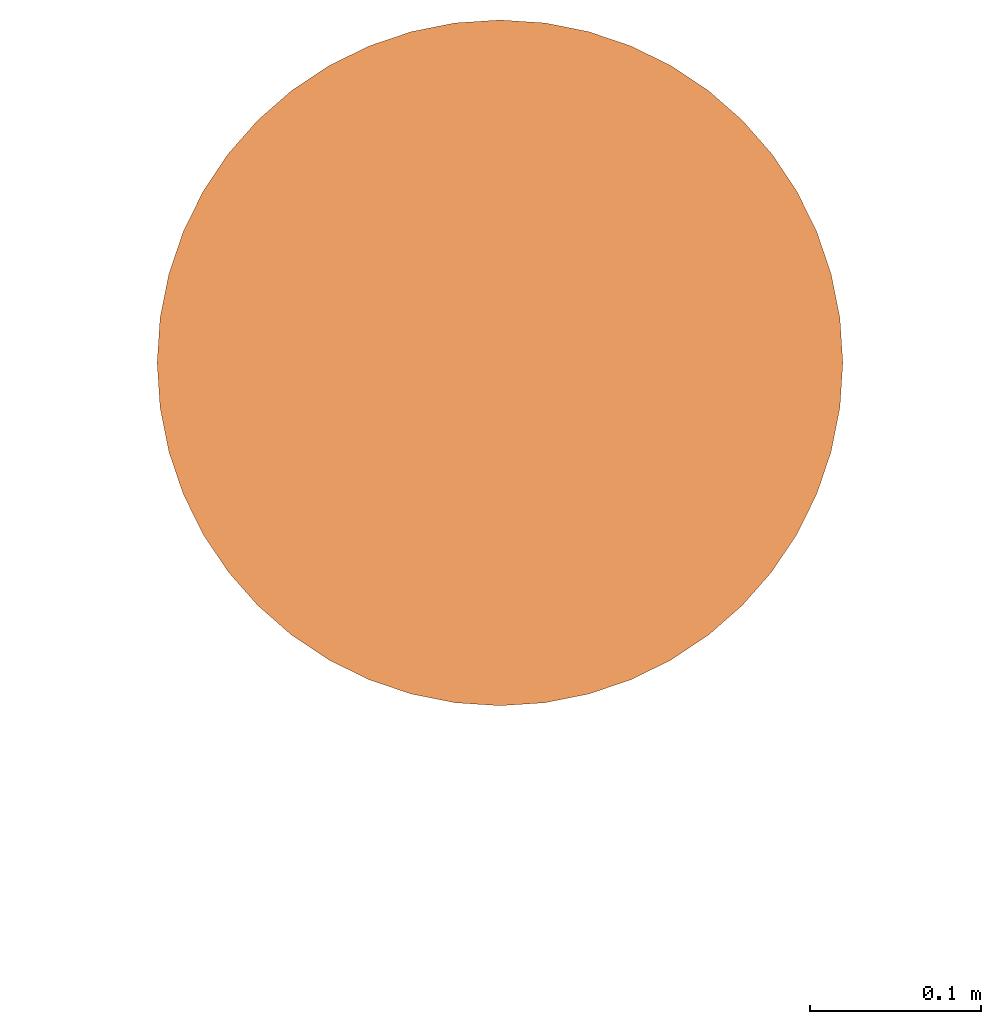
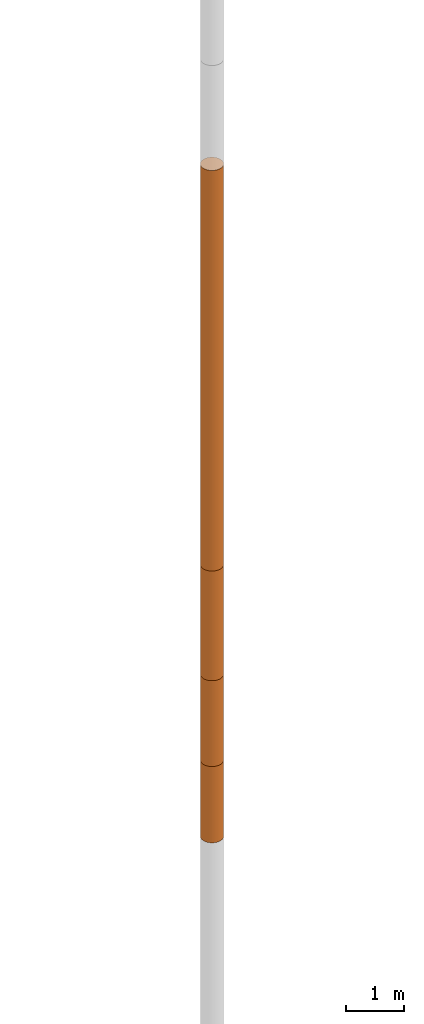
# Not in any storey, part 4 of 5: 4 geographic elements.
"""IFC4 model written with IfcOpenShell, lengths in metres."""

from ifc_helpers import new_model, entity, si_unit, converted_unit, frame, frame_2d, origin_with_axes, place, context, subcontext, project, spatial, polygons, element, save


model = new_model("IFC4")

# Units and contexts
model_context = context("Model", 3, precision=1e-05, world=origin_with_axes())
plan_context = context("Plan", 2, precision=1e-05, world=frame_2d((0.0, 0.0, 0.0), x_axis=(1.0, 0.0, 0.0)))
body_context = subcontext(model_context, "Body", "Model", "MODEL_VIEW")
ifc_project = project(units=[si_unit("VOLUMEUNIT", "CUBIC_METRE"), si_unit("LENGTHUNIT", "METRE"), converted_unit("PLANEANGLEUNIT", "degree", entity("IfcReal", 0.0174532925199433), si_unit("PLANEANGLEUNIT", "RADIAN"), dimensions=[0, 0, 0, 0, 0, 0, 0]), si_unit("AREAUNIT", "SQUARE_METRE")], contexts=[model_context, plan_context])

# Site
site_placement = place(None, origin_with_axes())
site = spatial("IfcSite", under=ifc_project, at=site_placement)

# Geographic elements
geographic_element_1_placement = place(site_placement, frame((19.3999996185303, 90.9000015258789, 3.20000457763672), z_axis=(0.0, 0.0, 1.0), x_axis=(1.0, 0.0, 0.0)))
element("IfcGeographicElement", 1, at=geographic_element_1_placement, inside=site, Name="BH_1_L_4", PredefinedType="NOTDEFINED", context=body_context, shape_type="Tessellation", body=[
    polygons([(0.0, 0.200000002980232, -4.19999980926514), (0.0, 0.200000002980232, 4.19999980926514), (0.0261052399873734, 0.198288977146149, -4.19999980926514), (0.0261052399873734, 0.198288977146149, 4.19999980926514), (0.0517638102173805, 0.193185165524483, -4.19999980926514), (0.0517638102173805, 0.193185165524483, 4.19999980926514), (0.0765366926789284, 0.184775903820992, -4.19999980926514), (0.0765366926789284, 0.184775903820992, 4.19999980926514), (0.100000001490116, 0.173205077648163, -4.19999980926514), (0.100000001490116, 0.173205077648163, 4.19999980926514), (0.12175228446722, 0.158670663833618, -4.19999980926514), (0.12175228446722, 0.158670663833618, 4.19999980926514), (0.141421362757683, 0.141421362757683, -4.19999980926514), (0.141421362757683, 0.141421362757683, 4.19999980926514), (0.158670663833618, 0.12175228446722, -4.19999980926514), (0.158670663833618, 0.12175228446722, 4.19999980926514), (0.173205077648163, 0.100000001490116, -4.19999980926514), (0.173205077648163, 0.100000001490116, 4.19999980926514), (0.184775903820992, 0.0765366926789284, -4.19999980926514), (0.184775903820992, 0.0765366926789284, 4.19999980926514), (0.193185165524483, 0.0517638102173805, -4.19999980926514), (0.193185165524483, 0.0517638102173805, 4.19999980926514), (0.198288977146149, 0.0261052399873734, -4.19999980926514), (0.198288977146149, 0.0261052399873734, 4.19999980926514), (0.200000002980232, 0.0, -4.19999980926514), (0.200000002980232, 0.0, 4.19999980926514), (0.198288977146149, -0.0261052399873734, -4.19999980926514), (0.198288977146149, -0.0261052399873734, 4.19999980926514), (0.193185165524483, -0.0517638102173805, -4.19999980926514), (0.193185165524483, -0.0517638102173805, 4.19999980926514), (0.184775903820992, -0.0765366926789284, -4.19999980926514), (0.184775903820992, -0.0765366926789284, 4.19999980926514), (0.173205077648163, -0.100000001490116, -4.19999980926514), (0.173205077648163, -0.100000001490116, 4.19999980926514), (0.158670663833618, -0.12175228446722, -4.19999980926514), (0.158670663833618, -0.12175228446722, 4.19999980926514), (0.141421362757683, -0.141421362757683, -4.19999980926514), (0.141421362757683, -0.141421362757683, 4.19999980926514), (0.12175228446722, -0.158670663833618, -4.19999980926514), (0.12175228446722, -0.158670663833618, 4.19999980926514), (0.100000001490116, -0.173205077648163, -4.19999980926514), (0.100000001490116, -0.173205077648163, 4.19999980926514), (0.0765366926789284, -0.184775903820992, -4.19999980926514), (0.0765366926789284, -0.184775903820992, 4.19999980926514), (0.0517638102173805, -0.193185165524483, -4.19999980926514), (0.0517638102173805, -0.193185165524483, 4.19999980926514), (0.0261052399873734, -0.198288977146149, -4.19999980926514), (0.0261052399873734, -0.198288977146149, 4.19999980926514), (0.0, -0.200000002980232, -4.19999980926514), (0.0, -0.200000002980232, 4.19999980926514), (-0.0261052399873734, -0.198288977146149, -4.19999980926514), (-0.0261052399873734, -0.198288977146149, 4.19999980926514), (-0.0517638102173805, -0.193185165524483, -4.19999980926514), (-0.0517638102173805, -0.193185165524483, 4.19999980926514), (-0.0765366926789284, -0.184775903820992, -4.19999980926514), (-0.0765366926789284, -0.184775903820992, 4.19999980926514), (-0.100000001490116, -0.173205077648163, -4.19999980926514), (-0.100000001490116, -0.173205077648163, 4.19999980926514), (-0.12175228446722, -0.158670663833618, -4.19999980926514), (-0.12175228446722, -0.158670663833618, 4.19999980926514), (-0.141421362757683, -0.141421362757683, -4.19999980926514), (-0.141421362757683, -0.141421362757683, 4.19999980926514), (-0.158670663833618, -0.12175228446722, -4.19999980926514), (-0.158670663833618, -0.12175228446722, 4.19999980926514), (-0.173205077648163, -0.100000001490116, -4.19999980926514), (-0.173205077648163, -0.100000001490116, 4.19999980926514), (-0.184775903820992, -0.0765366926789284, -4.19999980926514), (-0.184775903820992, -0.0765366926789284, 4.19999980926514), (-0.193185165524483, -0.0517638102173805, -4.19999980926514), (-0.193185165524483, -0.0517638102173805, 4.19999980926514), (-0.198288977146149, -0.0261052399873734, -4.19999980926514), (-0.198288977146149, -0.0261052399873734, 4.19999980926514), (-0.200000002980232, 0.0, -4.19999980926514), (-0.200000002980232, 0.0, 4.19999980926514), (-0.198288977146149, 0.0261052399873734, -4.19999980926514), (-0.198288977146149, 0.0261052399873734, 4.19999980926514), (-0.193185165524483, 0.0517638102173805, -4.19999980926514), (-0.193185165524483, 0.0517638102173805, 4.19999980926514), (-0.184775903820992, 0.0765366926789284, -4.19999980926514), (-0.184775903820992, 0.0765366926789284, 4.19999980926514), (-0.173205077648163, 0.100000001490116, -4.19999980926514), (-0.173205077648163, 0.100000001490116, 4.19999980926514), (-0.158670663833618, 0.12175228446722, -4.19999980926514), (-0.158670663833618, 0.12175228446722, 4.19999980926514), (-0.141421362757683, 0.141421362757683, -4.19999980926514), (-0.141421362757683, 0.141421362757683, 4.19999980926514), (-0.12175228446722, 0.158670663833618, -4.19999980926514), (-0.12175228446722, 0.158670663833618, 4.19999980926514), (-0.100000001490116, 0.173205077648163, -4.19999980926514), (-0.100000001490116, 0.173205077648163, 4.19999980926514), (-0.0765366926789284, 0.184775903820992, -4.19999980926514), (-0.0765366926789284, 0.184775903820992, 4.19999980926514), (-0.0517638102173805, 0.193185165524483, -4.19999980926514), (-0.0517638102173805, 0.193185165524483, 4.19999980926514), (-0.0261052399873734, 0.198288977146149, -4.19999980926514), (-0.0261052399873734, 0.198288977146149, 4.19999980926514)], [[[1, 2, 4, 3]], [[3, 4, 6, 5]], [[5, 6, 8, 7]], [[7, 8, 10, 9]], [[9, 10, 12, 11]], [[11, 12, 14, 13]], [[13, 14, 16, 15]], [[15, 16, 18, 17]], [[17, 18, 20, 19]], [[19, 20, 22, 21]], [[21, 22, 24, 23]], [[23, 24, 26, 25]], [[25, 26, 28, 27]], [[27, 28, 30, 29]], [[29, 30, 32, 31]], [[31, 32, 34, 33]], [[33, 34, 36, 35]], [[35, 36, 38, 37]], [[37, 38, 40, 39]], [[39, 40, 42, 41]], [[41, 42, 44, 43]], [[43, 44, 46, 45]], [[45, 46, 48, 47]], [[47, 48, 50, 49]], [[49, 50, 52, 51]], [[51, 52, 54, 53]], [[53, 54, 56, 55]], [[55, 56, 58, 57]], [[57, 58, 60, 59]], [[59, 60, 62, 61]], [[61, 62, 64, 63]], [[63, 64, 66, 65]], [[65, 66, 68, 67]], [[67, 68, 70, 69]], [[69, 70, 72, 71]], [[71, 72, 74, 73]], [[73, 74, 76, 75]], [[75, 76, 78, 77]], [[77, 78, 80, 79]], [[79, 80, 82, 81]], [[81, 82, 84, 83]], [[83, 84, 86, 85]], [[85, 86, 88, 87]], [[87, 88, 90, 89]], [[89, 90, 92, 91]], [[91, 92, 94, 93]], [[4, 2, 96, 94, 92, 90, 88, 86, 84, 82, 80, 78, 76, 74, 72, 70, 68, 66, 64, 62, 60, 58, 56, 54, 52, 50, 48, 46, 44, 42, 40, 38, 36, 34, 32, 30, 28, 26, 24, 22, 20, 18, 16, 14, 12, 10, 8, 6]], [[93, 94, 96, 95]], [[95, 96, 2, 1]], [[1, 3, 5, 7, 9, 11, 13, 15, 17, 19, 21, 23, 25, 27, 29, 31, 33, 35, 37, 39, 41, 43, 45, 47, 49, 51, 53, 55, 57, 59, 61, 63, 65, 67, 69, 71, 73, 75, 77, 79, 81, 83, 85, 87, 89, 91, 93, 95]]]),
])
geographic_element_2_placement = place(site_placement, frame((19.3999996185303, 90.9000015258789, -2.14999341964722), z_axis=(0.0, 0.0, 1.0), x_axis=(1.0, 0.0, 0.0)))
element("IfcGeographicElement", 2, at=geographic_element_2_placement, inside=site, Name="BH_1_L_5", PredefinedType="NOTDEFINED", context=body_context, shape_type="Tessellation", body=[
    polygons([(0.0, 0.200000002980232, -1.14999997615814), (0.0, 0.200000002980232, 1.14999997615814), (0.0261052399873734, 0.198288977146149, -1.14999997615814), (0.0261052399873734, 0.198288977146149, 1.14999997615814), (0.0517638102173805, 0.193185165524483, -1.14999997615814), (0.0517638102173805, 0.193185165524483, 1.14999997615814), (0.0765366926789284, 0.184775903820992, -1.14999997615814), (0.0765366926789284, 0.184775903820992, 1.14999997615814), (0.100000001490116, 0.173205077648163, -1.14999997615814), (0.100000001490116, 0.173205077648163, 1.14999997615814), (0.12175228446722, 0.158670663833618, -1.14999997615814), (0.12175228446722, 0.158670663833618, 1.14999997615814), (0.141421362757683, 0.141421362757683, -1.14999997615814), (0.141421362757683, 0.141421362757683, 1.14999997615814), (0.158670663833618, 0.12175228446722, -1.14999997615814), (0.158670663833618, 0.12175228446722, 1.14999997615814), (0.173205077648163, 0.100000001490116, -1.14999997615814), (0.173205077648163, 0.100000001490116, 1.14999997615814), (0.184775903820992, 0.0765366926789284, -1.14999997615814), (0.184775903820992, 0.0765366926789284, 1.14999997615814), (0.193185165524483, 0.0517638102173805, -1.14999997615814), (0.193185165524483, 0.0517638102173805, 1.14999997615814), (0.198288977146149, 0.0261052399873734, -1.14999997615814), (0.198288977146149, 0.0261052399873734, 1.14999997615814), (0.200000002980232, 0.0, -1.14999997615814), (0.200000002980232, 0.0, 1.14999997615814), (0.198288977146149, -0.0261052399873734, -1.14999997615814), (0.198288977146149, -0.0261052399873734, 1.14999997615814), (0.193185165524483, -0.0517638102173805, -1.14999997615814), (0.193185165524483, -0.0517638102173805, 1.14999997615814), (0.184775903820992, -0.0765366926789284, -1.14999997615814), (0.184775903820992, -0.0765366926789284, 1.14999997615814), (0.173205077648163, -0.100000001490116, -1.14999997615814), (0.173205077648163, -0.100000001490116, 1.14999997615814), (0.158670663833618, -0.12175228446722, -1.14999997615814), (0.158670663833618, -0.12175228446722, 1.14999997615814), (0.141421362757683, -0.141421362757683, -1.14999997615814), (0.141421362757683, -0.141421362757683, 1.14999997615814), (0.12175228446722, -0.158670663833618, -1.14999997615814), (0.12175228446722, -0.158670663833618, 1.14999997615814), (0.100000001490116, -0.173205077648163, -1.14999997615814), (0.100000001490116, -0.173205077648163, 1.14999997615814), (0.0765366926789284, -0.184775903820992, -1.14999997615814), (0.0765366926789284, -0.184775903820992, 1.14999997615814), (0.0517638102173805, -0.193185165524483, -1.14999997615814), (0.0517638102173805, -0.193185165524483, 1.14999997615814), (0.0261052399873734, -0.198288977146149, -1.14999997615814), (0.0261052399873734, -0.198288977146149, 1.14999997615814), (0.0, -0.200000002980232, -1.14999997615814), (0.0, -0.200000002980232, 1.14999997615814), (-0.0261052399873734, -0.198288977146149, -1.14999997615814), (-0.0261052399873734, -0.198288977146149, 1.14999997615814), (-0.0517638102173805, -0.193185165524483, -1.14999997615814), (-0.0517638102173805, -0.193185165524483, 1.14999997615814), (-0.0765366926789284, -0.184775903820992, -1.14999997615814), (-0.0765366926789284, -0.184775903820992, 1.14999997615814), (-0.100000001490116, -0.173205077648163, -1.14999997615814), (-0.100000001490116, -0.173205077648163, 1.14999997615814), (-0.12175228446722, -0.158670663833618, -1.14999997615814), (-0.12175228446722, -0.158670663833618, 1.14999997615814), (-0.141421362757683, -0.141421362757683, -1.14999997615814), (-0.141421362757683, -0.141421362757683, 1.14999997615814), (-0.158670663833618, -0.12175228446722, -1.14999997615814), (-0.158670663833618, -0.12175228446722, 1.14999997615814), (-0.173205077648163, -0.100000001490116, -1.14999997615814), (-0.173205077648163, -0.100000001490116, 1.14999997615814), (-0.184775903820992, -0.0765366926789284, -1.14999997615814), (-0.184775903820992, -0.0765366926789284, 1.14999997615814), (-0.193185165524483, -0.0517638102173805, -1.14999997615814), (-0.193185165524483, -0.0517638102173805, 1.14999997615814), (-0.198288977146149, -0.0261052399873734, -1.14999997615814), (-0.198288977146149, -0.0261052399873734, 1.14999997615814), (-0.200000002980232, 0.0, -1.14999997615814), (-0.200000002980232, 0.0, 1.14999997615814), (-0.198288977146149, 0.0261052399873734, -1.14999997615814), (-0.198288977146149, 0.0261052399873734, 1.14999997615814), (-0.193185165524483, 0.0517638102173805, -1.14999997615814), (-0.193185165524483, 0.0517638102173805, 1.14999997615814), (-0.184775903820992, 0.0765366926789284, -1.14999997615814), (-0.184775903820992, 0.0765366926789284, 1.14999997615814), (-0.173205077648163, 0.100000001490116, -1.14999997615814), (-0.173205077648163, 0.100000001490116, 1.14999997615814), (-0.158670663833618, 0.12175228446722, -1.14999997615814), (-0.158670663833618, 0.12175228446722, 1.14999997615814), (-0.141421362757683, 0.141421362757683, -1.14999997615814), (-0.141421362757683, 0.141421362757683, 1.14999997615814), (-0.12175228446722, 0.158670663833618, -1.14999997615814), (-0.12175228446722, 0.158670663833618, 1.14999997615814), (-0.100000001490116, 0.173205077648163, -1.14999997615814), (-0.100000001490116, 0.173205077648163, 1.14999997615814), (-0.0765366926789284, 0.184775903820992, -1.14999997615814), (-0.0765366926789284, 0.184775903820992, 1.14999997615814), (-0.0517638102173805, 0.193185165524483, -1.14999997615814), (-0.0517638102173805, 0.193185165524483, 1.14999997615814), (-0.0261052399873734, 0.198288977146149, -1.14999997615814), (-0.0261052399873734, 0.198288977146149, 1.14999997615814)], [[[1, 2, 4, 3]], [[3, 4, 6, 5]], [[5, 6, 8, 7]], [[7, 8, 10, 9]], [[9, 10, 12, 11]], [[11, 12, 14, 13]], [[13, 14, 16, 15]], [[15, 16, 18, 17]], [[17, 18, 20, 19]], [[19, 20, 22, 21]], [[21, 22, 24, 23]], [[23, 24, 26, 25]], [[25, 26, 28, 27]], [[27, 28, 30, 29]], [[29, 30, 32, 31]], [[31, 32, 34, 33]], [[33, 34, 36, 35]], [[35, 36, 38, 37]], [[37, 38, 40, 39]], [[39, 40, 42, 41]], [[41, 42, 44, 43]], [[43, 44, 46, 45]], [[45, 46, 48, 47]], [[47, 48, 50, 49]], [[49, 50, 52, 51]], [[51, 52, 54, 53]], [[53, 54, 56, 55]], [[55, 56, 58, 57]], [[57, 58, 60, 59]], [[59, 60, 62, 61]], [[61, 62, 64, 63]], [[63, 64, 66, 65]], [[65, 66, 68, 67]], [[67, 68, 70, 69]], [[69, 70, 72, 71]], [[71, 72, 74, 73]], [[73, 74, 76, 75]], [[75, 76, 78, 77]], [[77, 78, 80, 79]], [[79, 80, 82, 81]], [[81, 82, 84, 83]], [[83, 84, 86, 85]], [[85, 86, 88, 87]], [[87, 88, 90, 89]], [[89, 90, 92, 91]], [[91, 92, 94, 93]], [[4, 2, 96, 94, 92, 90, 88, 86, 84, 82, 80, 78, 76, 74, 72, 70, 68, 66, 64, 62, 60, 58, 56, 54, 52, 50, 48, 46, 44, 42, 40, 38, 36, 34, 32, 30, 28, 26, 24, 22, 20, 18, 16, 14, 12, 10, 8, 6]], [[93, 94, 96, 95]], [[95, 96, 2, 1]], [[1, 3, 5, 7, 9, 11, 13, 15, 17, 19, 21, 23, 25, 27, 29, 31, 33, 35, 37, 39, 41, 43, 45, 47, 49, 51, 53, 55, 57, 59, 61, 63, 65, 67, 69, 71, 73, 75, 77, 79, 81, 83, 85, 87, 89, 91, 93, 95]]]),
])
geographic_element_3_placement = place(site_placement, frame((19.3999996185303, 90.9000015258789, -4.19999265670776), z_axis=(0.0, 0.0, 1.0), x_axis=(1.0, 0.0, 0.0)))
element("IfcGeographicElement", 3, at=geographic_element_3_placement, inside=site, Name="BH_1_L_6", PredefinedType="NOTDEFINED", context=body_context, shape_type="Tessellation", body=[
    polygons([(0.0, 0.200000002980232, -0.899999976158142), (0.0, 0.200000002980232, 0.899999976158142), (0.0261052399873734, 0.198288977146149, -0.899999976158142), (0.0261052399873734, 0.198288977146149, 0.899999976158142), (0.0517638102173805, 0.193185165524483, -0.899999976158142), (0.0517638102173805, 0.193185165524483, 0.899999976158142), (0.0765366926789284, 0.184775903820992, -0.899999976158142), (0.0765366926789284, 0.184775903820992, 0.899999976158142), (0.100000001490116, 0.173205077648163, -0.899999976158142), (0.100000001490116, 0.173205077648163, 0.899999976158142), (0.12175228446722, 0.158670663833618, -0.899999976158142), (0.12175228446722, 0.158670663833618, 0.899999976158142), (0.141421362757683, 0.141421362757683, -0.899999976158142), (0.141421362757683, 0.141421362757683, 0.899999976158142), (0.158670663833618, 0.12175228446722, -0.899999976158142), (0.158670663833618, 0.12175228446722, 0.899999976158142), (0.173205077648163, 0.100000001490116, -0.899999976158142), (0.173205077648163, 0.100000001490116, 0.899999976158142), (0.184775903820992, 0.0765366926789284, -0.899999976158142), (0.184775903820992, 0.0765366926789284, 0.899999976158142), (0.193185165524483, 0.0517638102173805, -0.899999976158142), (0.193185165524483, 0.0517638102173805, 0.899999976158142), (0.198288977146149, 0.0261052399873734, -0.899999976158142), (0.198288977146149, 0.0261052399873734, 0.899999976158142), (0.200000002980232, 0.0, -0.899999976158142), (0.200000002980232, 0.0, 0.899999976158142), (0.198288977146149, -0.0261052399873734, -0.899999976158142), (0.198288977146149, -0.0261052399873734, 0.899999976158142), (0.193185165524483, -0.0517638102173805, -0.899999976158142), (0.193185165524483, -0.0517638102173805, 0.899999976158142), (0.184775903820992, -0.0765366926789284, -0.899999976158142), (0.184775903820992, -0.0765366926789284, 0.899999976158142), (0.173205077648163, -0.100000001490116, -0.899999976158142), (0.173205077648163, -0.100000001490116, 0.899999976158142), (0.158670663833618, -0.12175228446722, -0.899999976158142), (0.158670663833618, -0.12175228446722, 0.899999976158142), (0.141421362757683, -0.141421362757683, -0.899999976158142), (0.141421362757683, -0.141421362757683, 0.899999976158142), (0.12175228446722, -0.158670663833618, -0.899999976158142), (0.12175228446722, -0.158670663833618, 0.899999976158142), (0.100000001490116, -0.173205077648163, -0.899999976158142), (0.100000001490116, -0.173205077648163, 0.899999976158142), (0.0765366926789284, -0.184775903820992, -0.899999976158142), (0.0765366926789284, -0.184775903820992, 0.899999976158142), (0.0517638102173805, -0.193185165524483, -0.899999976158142), (0.0517638102173805, -0.193185165524483, 0.899999976158142), (0.0261052399873734, -0.198288977146149, -0.899999976158142), (0.0261052399873734, -0.198288977146149, 0.899999976158142), (0.0, -0.200000002980232, -0.899999976158142), (0.0, -0.200000002980232, 0.899999976158142), (-0.0261052399873734, -0.198288977146149, -0.899999976158142), (-0.0261052399873734, -0.198288977146149, 0.899999976158142), (-0.0517638102173805, -0.193185165524483, -0.899999976158142), (-0.0517638102173805, -0.193185165524483, 0.899999976158142), (-0.0765366926789284, -0.184775903820992, -0.899999976158142), (-0.0765366926789284, -0.184775903820992, 0.899999976158142), (-0.100000001490116, -0.173205077648163, -0.899999976158142), (-0.100000001490116, -0.173205077648163, 0.899999976158142), (-0.12175228446722, -0.158670663833618, -0.899999976158142), (-0.12175228446722, -0.158670663833618, 0.899999976158142), (-0.141421362757683, -0.141421362757683, -0.899999976158142), (-0.141421362757683, -0.141421362757683, 0.899999976158142), (-0.158670663833618, -0.12175228446722, -0.899999976158142), (-0.158670663833618, -0.12175228446722, 0.899999976158142), (-0.173205077648163, -0.100000001490116, -0.899999976158142), (-0.173205077648163, -0.100000001490116, 0.899999976158142), (-0.184775903820992, -0.0765366926789284, -0.899999976158142), (-0.184775903820992, -0.0765366926789284, 0.899999976158142), (-0.193185165524483, -0.0517638102173805, -0.899999976158142), (-0.193185165524483, -0.0517638102173805, 0.899999976158142), (-0.198288977146149, -0.0261052399873734, -0.899999976158142), (-0.198288977146149, -0.0261052399873734, 0.899999976158142), (-0.200000002980232, 0.0, -0.899999976158142), (-0.200000002980232, 0.0, 0.899999976158142), (-0.198288977146149, 0.0261052399873734, -0.899999976158142), (-0.198288977146149, 0.0261052399873734, 0.899999976158142), (-0.193185165524483, 0.0517638102173805, -0.899999976158142), (-0.193185165524483, 0.0517638102173805, 0.899999976158142), (-0.184775903820992, 0.0765366926789284, -0.899999976158142), (-0.184775903820992, 0.0765366926789284, 0.899999976158142), (-0.173205077648163, 0.100000001490116, -0.899999976158142), (-0.173205077648163, 0.100000001490116, 0.899999976158142), (-0.158670663833618, 0.12175228446722, -0.899999976158142), (-0.158670663833618, 0.12175228446722, 0.899999976158142), (-0.141421362757683, 0.141421362757683, -0.899999976158142), (-0.141421362757683, 0.141421362757683, 0.899999976158142), (-0.12175228446722, 0.158670663833618, -0.899999976158142), (-0.12175228446722, 0.158670663833618, 0.899999976158142), (-0.100000001490116, 0.173205077648163, -0.899999976158142), (-0.100000001490116, 0.173205077648163, 0.899999976158142), (-0.0765366926789284, 0.184775903820992, -0.899999976158142), (-0.0765366926789284, 0.184775903820992, 0.899999976158142), (-0.0517638102173805, 0.193185165524483, -0.899999976158142), (-0.0517638102173805, 0.193185165524483, 0.899999976158142), (-0.0261052399873734, 0.198288977146149, -0.899999976158142), (-0.0261052399873734, 0.198288977146149, 0.899999976158142)], [[[1, 2, 4, 3]], [[3, 4, 6, 5]], [[5, 6, 8, 7]], [[7, 8, 10, 9]], [[9, 10, 12, 11]], [[11, 12, 14, 13]], [[13, 14, 16, 15]], [[15, 16, 18, 17]], [[17, 18, 20, 19]], [[19, 20, 22, 21]], [[21, 22, 24, 23]], [[23, 24, 26, 25]], [[25, 26, 28, 27]], [[27, 28, 30, 29]], [[29, 30, 32, 31]], [[31, 32, 34, 33]], [[33, 34, 36, 35]], [[35, 36, 38, 37]], [[37, 38, 40, 39]], [[39, 40, 42, 41]], [[41, 42, 44, 43]], [[43, 44, 46, 45]], [[45, 46, 48, 47]], [[47, 48, 50, 49]], [[49, 50, 52, 51]], [[51, 52, 54, 53]], [[53, 54, 56, 55]], [[55, 56, 58, 57]], [[57, 58, 60, 59]], [[59, 60, 62, 61]], [[61, 62, 64, 63]], [[63, 64, 66, 65]], [[65, 66, 68, 67]], [[67, 68, 70, 69]], [[69, 70, 72, 71]], [[71, 72, 74, 73]], [[73, 74, 76, 75]], [[75, 76, 78, 77]], [[77, 78, 80, 79]], [[79, 80, 82, 81]], [[81, 82, 84, 83]], [[83, 84, 86, 85]], [[85, 86, 88, 87]], [[87, 88, 90, 89]], [[89, 90, 92, 91]], [[91, 92, 94, 93]], [[4, 2, 96, 94, 92, 90, 88, 86, 84, 82, 80, 78, 76, 74, 72, 70, 68, 66, 64, 62, 60, 58, 56, 54, 52, 50, 48, 46, 44, 42, 40, 38, 36, 34, 32, 30, 28, 26, 24, 22, 20, 18, 16, 14, 12, 10, 8, 6]], [[93, 94, 96, 95]], [[95, 96, 2, 1]], [[1, 3, 5, 7, 9, 11, 13, 15, 17, 19, 21, 23, 25, 27, 29, 31, 33, 35, 37, 39, 41, 43, 45, 47, 49, 51, 53, 55, 57, 59, 61, 63, 65, 67, 69, 71, 73, 75, 77, 79, 81, 83, 85, 87, 89, 91, 93, 95]]]),
])
geographic_element_4_placement = place(site_placement, frame((19.3999996185303, 90.9000015258789, -5.89999198913574), z_axis=(0.0, 0.0, 1.0), x_axis=(1.0, 0.0, 0.0)))
element("IfcGeographicElement", 4, at=geographic_element_4_placement, inside=site, Name="BH_1_L_7", PredefinedType="NOTDEFINED", context=body_context, shape_type="Tessellation", body=[
    polygons([(0.0, 0.200000002980232, -0.800000011920929), (0.0, 0.200000002980232, 0.800000011920929), (0.0261052399873734, 0.198288977146149, -0.800000011920929), (0.0261052399873734, 0.198288977146149, 0.800000011920929), (0.0517638102173805, 0.193185165524483, -0.800000011920929), (0.0517638102173805, 0.193185165524483, 0.800000011920929), (0.0765366926789284, 0.184775903820992, -0.800000011920929), (0.0765366926789284, 0.184775903820992, 0.800000011920929), (0.100000001490116, 0.173205077648163, -0.800000011920929), (0.100000001490116, 0.173205077648163, 0.800000011920929), (0.12175228446722, 0.158670663833618, -0.800000011920929), (0.12175228446722, 0.158670663833618, 0.800000011920929), (0.141421362757683, 0.141421362757683, -0.800000011920929), (0.141421362757683, 0.141421362757683, 0.800000011920929), (0.158670663833618, 0.12175228446722, -0.800000011920929), (0.158670663833618, 0.12175228446722, 0.800000011920929), (0.173205077648163, 0.100000001490116, -0.800000011920929), (0.173205077648163, 0.100000001490116, 0.800000011920929), (0.184775903820992, 0.0765366926789284, -0.800000011920929), (0.184775903820992, 0.0765366926789284, 0.800000011920929), (0.193185165524483, 0.0517638102173805, -0.800000011920929), (0.193185165524483, 0.0517638102173805, 0.800000011920929), (0.198288977146149, 0.0261052399873734, -0.800000011920929), (0.198288977146149, 0.0261052399873734, 0.800000011920929), (0.200000002980232, 0.0, -0.800000011920929), (0.200000002980232, 0.0, 0.800000011920929), (0.198288977146149, -0.0261052399873734, -0.800000011920929), (0.198288977146149, -0.0261052399873734, 0.800000011920929), (0.193185165524483, -0.0517638102173805, -0.800000011920929), (0.193185165524483, -0.0517638102173805, 0.800000011920929), (0.184775903820992, -0.0765366926789284, -0.800000011920929), (0.184775903820992, -0.0765366926789284, 0.800000011920929), (0.173205077648163, -0.100000001490116, -0.800000011920929), (0.173205077648163, -0.100000001490116, 0.800000011920929), (0.158670663833618, -0.12175228446722, -0.800000011920929), (0.158670663833618, -0.12175228446722, 0.800000011920929), (0.141421362757683, -0.141421362757683, -0.800000011920929), (0.141421362757683, -0.141421362757683, 0.800000011920929), (0.12175228446722, -0.158670663833618, -0.800000011920929), (0.12175228446722, -0.158670663833618, 0.800000011920929), (0.100000001490116, -0.173205077648163, -0.800000011920929), (0.100000001490116, -0.173205077648163, 0.800000011920929), (0.0765366926789284, -0.184775903820992, -0.800000011920929), (0.0765366926789284, -0.184775903820992, 0.800000011920929), (0.0517638102173805, -0.193185165524483, -0.800000011920929), (0.0517638102173805, -0.193185165524483, 0.800000011920929), (0.0261052399873734, -0.198288977146149, -0.800000011920929), (0.0261052399873734, -0.198288977146149, 0.800000011920929), (0.0, -0.200000002980232, -0.800000011920929), (0.0, -0.200000002980232, 0.800000011920929), (-0.0261052399873734, -0.198288977146149, -0.800000011920929), (-0.0261052399873734, -0.198288977146149, 0.800000011920929), (-0.0517638102173805, -0.193185165524483, -0.800000011920929), (-0.0517638102173805, -0.193185165524483, 0.800000011920929), (-0.0765366926789284, -0.184775903820992, -0.800000011920929), (-0.0765366926789284, -0.184775903820992, 0.800000011920929), (-0.100000001490116, -0.173205077648163, -0.800000011920929), (-0.100000001490116, -0.173205077648163, 0.800000011920929), (-0.12175228446722, -0.158670663833618, -0.800000011920929), (-0.12175228446722, -0.158670663833618, 0.800000011920929), (-0.141421362757683, -0.141421362757683, -0.800000011920929), (-0.141421362757683, -0.141421362757683, 0.800000011920929), (-0.158670663833618, -0.12175228446722, -0.800000011920929), (-0.158670663833618, -0.12175228446722, 0.800000011920929), (-0.173205077648163, -0.100000001490116, -0.800000011920929), (-0.173205077648163, -0.100000001490116, 0.800000011920929), (-0.184775903820992, -0.0765366926789284, -0.800000011920929), (-0.184775903820992, -0.0765366926789284, 0.800000011920929), (-0.193185165524483, -0.0517638102173805, -0.800000011920929), (-0.193185165524483, -0.0517638102173805, 0.800000011920929), (-0.198288977146149, -0.0261052399873734, -0.800000011920929), (-0.198288977146149, -0.0261052399873734, 0.800000011920929), (-0.200000002980232, 0.0, -0.800000011920929), (-0.200000002980232, 0.0, 0.800000011920929), (-0.198288977146149, 0.0261052399873734, -0.800000011920929), (-0.198288977146149, 0.0261052399873734, 0.800000011920929), (-0.193185165524483, 0.0517638102173805, -0.800000011920929), (-0.193185165524483, 0.0517638102173805, 0.800000011920929), (-0.184775903820992, 0.0765366926789284, -0.800000011920929), (-0.184775903820992, 0.0765366926789284, 0.800000011920929), (-0.173205077648163, 0.100000001490116, -0.800000011920929), (-0.173205077648163, 0.100000001490116, 0.800000011920929), (-0.158670663833618, 0.12175228446722, -0.800000011920929), (-0.158670663833618, 0.12175228446722, 0.800000011920929), (-0.141421362757683, 0.141421362757683, -0.800000011920929), (-0.141421362757683, 0.141421362757683, 0.800000011920929), (-0.12175228446722, 0.158670663833618, -0.800000011920929), (-0.12175228446722, 0.158670663833618, 0.800000011920929), (-0.100000001490116, 0.173205077648163, -0.800000011920929), (-0.100000001490116, 0.173205077648163, 0.800000011920929), (-0.0765366926789284, 0.184775903820992, -0.800000011920929), (-0.0765366926789284, 0.184775903820992, 0.800000011920929), (-0.0517638102173805, 0.193185165524483, -0.800000011920929), (-0.0517638102173805, 0.193185165524483, 0.800000011920929), (-0.0261052399873734, 0.198288977146149, -0.800000011920929), (-0.0261052399873734, 0.198288977146149, 0.800000011920929)], [[[1, 2, 4, 3]], [[3, 4, 6, 5]], [[5, 6, 8, 7]], [[7, 8, 10, 9]], [[9, 10, 12, 11]], [[11, 12, 14, 13]], [[13, 14, 16, 15]], [[15, 16, 18, 17]], [[17, 18, 20, 19]], [[19, 20, 22, 21]], [[21, 22, 24, 23]], [[23, 24, 26, 25]], [[25, 26, 28, 27]], [[27, 28, 30, 29]], [[29, 30, 32, 31]], [[31, 32, 34, 33]], [[33, 34, 36, 35]], [[35, 36, 38, 37]], [[37, 38, 40, 39]], [[39, 40, 42, 41]], [[41, 42, 44, 43]], [[43, 44, 46, 45]], [[45, 46, 48, 47]], [[47, 48, 50, 49]], [[49, 50, 52, 51]], [[51, 52, 54, 53]], [[53, 54, 56, 55]], [[55, 56, 58, 57]], [[57, 58, 60, 59]], [[59, 60, 62, 61]], [[61, 62, 64, 63]], [[63, 64, 66, 65]], [[65, 66, 68, 67]], [[67, 68, 70, 69]], [[69, 70, 72, 71]], [[71, 72, 74, 73]], [[73, 74, 76, 75]], [[75, 76, 78, 77]], [[77, 78, 80, 79]], [[79, 80, 82, 81]], [[81, 82, 84, 83]], [[83, 84, 86, 85]], [[85, 86, 88, 87]], [[87, 88, 90, 89]], [[89, 90, 92, 91]], [[91, 92, 94, 93]], [[4, 2, 96, 94, 92, 90, 88, 86, 84, 82, 80, 78, 76, 74, 72, 70, 68, 66, 64, 62, 60, 58, 56, 54, 52, 50, 48, 46, 44, 42, 40, 38, 36, 34, 32, 30, 28, 26, 24, 22, 20, 18, 16, 14, 12, 10, 8, 6]], [[93, 94, 96, 95]], [[95, 96, 2, 1]], [[1, 3, 5, 7, 9, 11, 13, 15, 17, 19, 21, 23, 25, 27, 29, 31, 33, 35, 37, 39, 41, 43, 45, 47, 49, 51, 53, 55, 57, 59, 61, 63, 65, 67, 69, 71, 73, 75, 77, 79, 81, 83, 85, 87, 89, 91, 93, 95]]]),
])

save(model, "model.ifc")
